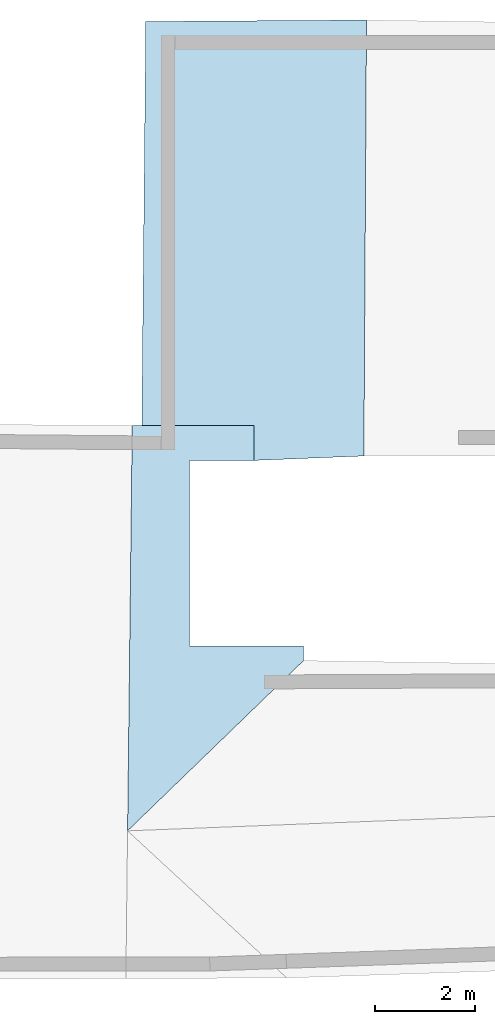
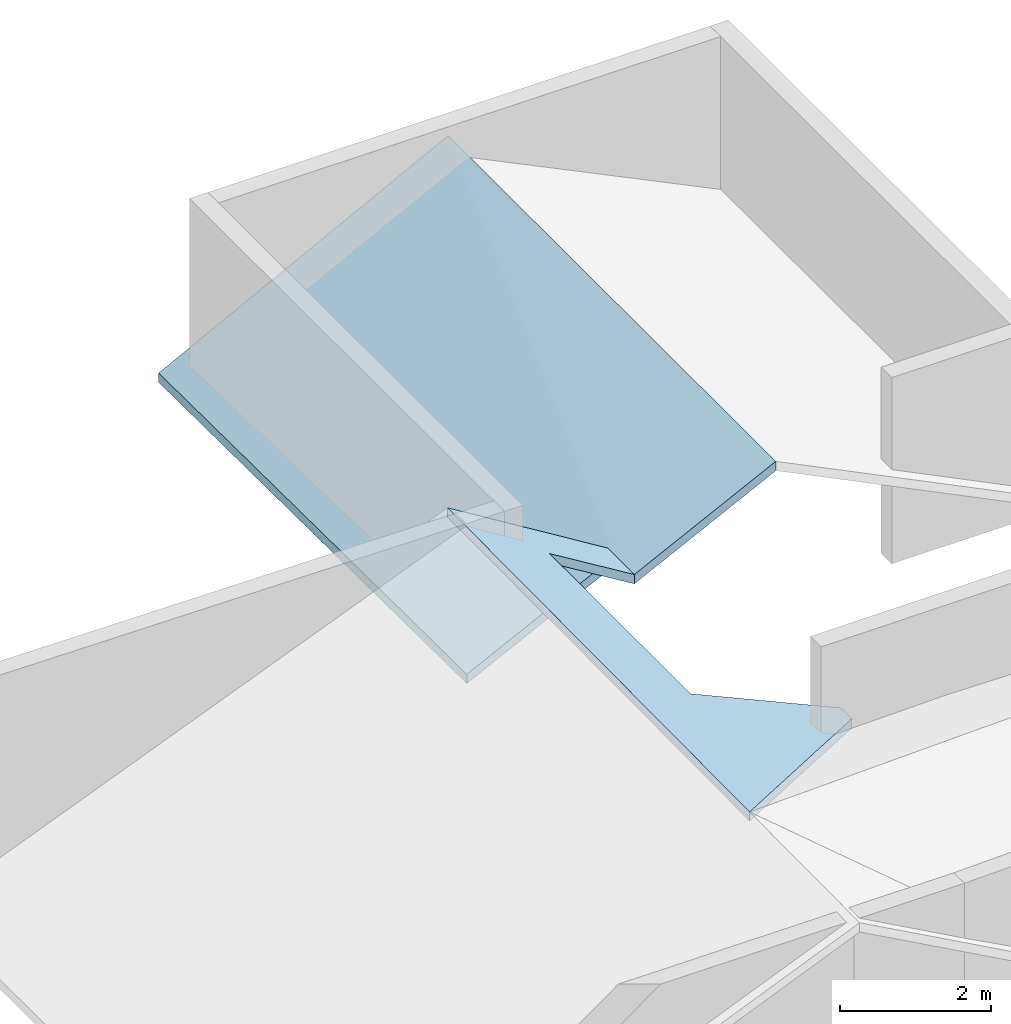
# One storey, part 2 of 2: 2 slabs.
"""IFC4 building model written with IfcOpenShell, lengths in metres."""

from ifc_helpers import new_model, entity, si_unit, converted_unit, frame, frame_2d, origin_with_axes, place, context, subcontext, project, spatial, polygons, element, save


model = new_model("IFC4")

# Units and contexts
model_context = context("Model", 3, precision=1e-05, world=origin_with_axes())
plan_context = context("Plan", 2, precision=1e-05, world=frame_2d((0.0, 0.0, 0.0), x_axis=(1.0, 0.0, 0.0)))
body_context = subcontext(model_context, "Body", "Model", "MODEL_VIEW")
ifc_project = project(units=[converted_unit("PLANEANGLEUNIT", "degree", entity("IfcReal", 0.0174532925199433), si_unit("PLANEANGLEUNIT", "RADIAN"), dimensions=[0, 0, 0, 0, 0, 0, 0]), si_unit("AREAUNIT", "SQUARE_METRE"), si_unit("VOLUMEUNIT", "CUBIC_METRE"), si_unit("LENGTHUNIT", "METRE")], contexts=[model_context, plan_context])

# Site, building, storey
site_placement = place(None, origin_with_axes())
site = spatial("IfcSite", under=ifc_project, at=site_placement)
building_placement = place(site_placement, origin_with_axes())
building = spatial("IfcBuilding", under=site, at=building_placement, Name="Building")
storey_placement = place(building_placement, frame((0.0, 0.0, 3.0), z_axis=(0.0, 0.0, 1.0), x_axis=(1.0, 0.0, 0.0)))
storey = spatial("IfcBuildingStorey", under=building, at=storey_placement, Name="Dachgeschoss")

# Slabs
slab_1_placement = place(storey_placement, frame((26.8203887939453, 9.78442668914795, -2.06702888011932), z_axis=(0.0, 0.0, 1.0), x_axis=(1.0, 0.0, 0.0)))
element("IfcSlab", 1, at=slab_1_placement, inside=storey, Name="dach_wohnen_w", PredefinedType="ROOF", context=body_context, shape_type="Tessellation", body=[
    polygons([(-18.3055820465088, -6.04181098937988, 5.09152317047119), (-14.7738656997681, -2.62468528747559, 3.28549098968506), (-18.2124099731445, 2.09556102752686, 5.02737331390381), (-17.0658378601074, 1.3901504278183, 4.31534337997437), (-15.7722063064575, 1.39000952243805, 3.52441787719727), (-15.7722063064575, 2.09556126594543, 3.52441787719727), (-14.7738656997681, -2.33506321907043, 3.28549098968506), (-17.0658378601074, -2.33499145507813, 4.31534337997437), (-18.2124099731445, 2.09556102752686, 4.87737321853638), (-18.3055820465088, -6.04181098937988, 4.94152307510376), (-14.7738656997681, -2.62468528747559, 3.13549089431763), (-15.7722063064575, 2.09556126594543, 3.37441778182983), (-17.0658378601074, 1.3901504278183, 4.16534328460693), (-15.7722063064575, 1.39000952243805, 3.37441778182983), (-14.7738656997681, -2.33506321907043, 3.13549089431763), (-17.0658378601074, -2.33499145507813, 4.16534328460693)], [[[1, 3, 8]], [[16, 13, 9]], [[7, 8, 16, 15]], [[5, 6, 12, 14]], [[6, 3, 9, 12]], [[3, 10, 9]], [[4, 16, 8]], [[2, 7, 15, 11]], [[4, 5, 14, 13]], [[1, 2, 11, 10]], [[3, 6, 4]], [[6, 5, 4]], [[7, 2, 8]], [[2, 1, 8]], [[3, 4, 8]], [[10, 11, 16]], [[11, 15, 16]], [[14, 12, 13]], [[12, 9, 13]], [[10, 16, 9]], [[3, 1, 10]], [[4, 13, 16]]]),
])
slab_2_placement = place(storey_placement, frame((11.5073595046997, 19.0338859558105, -0.612094879150391), z_axis=(0.0, 0.0, 1.0), x_axis=(1.0, 0.0, 0.0)))
element("IfcSlab", 2, at=slab_2_placement, inside=storey, Name="dach_so", PredefinedType="ROOF", context=body_context, shape_type="Tessellation", body=[
    polygons([(-2.97228264808655, -7.43174934387207, 0.821340084075928), (1.74949443340302, -7.77036571502686, 3.06659126281738), (-2.62752819061279, 0.947076737880707, 0.736433267593384), (1.80188846588135, 0.977355897426605, 2.99584007263184), (-0.459177732467651, -7.85944890975952, 2.06948375701904), (-2.70927309989929, -7.33231735229492, 0.930184245109558), (-0.459176629781723, -7.35307836532593, 2.06948399543762), (1.74949443340302, -7.77036571502686, 2.91659116744995), (1.80188846588135, 0.977355897426605, 2.8458399772644), (-2.62752819061279, 0.947076737880707, 0.586433291435242), (-2.70927309989929, -7.33231735229492, 0.780184268951416), (-0.459177732467651, -7.85944890975952, 1.9194837808609), (-0.459176629781723, -7.35307836532593, 1.91948401927948)], [[[2, 5, 7]], [[9, 10, 13]], [[6, 7, 13, 11]], [[4, 3, 10, 9]], [[3, 6, 11, 10]], [[5, 2, 8, 12]], [[7, 5, 12, 13]], [[2, 4, 9, 8]], [[7, 6, 3]], [[3, 4, 7]], [[4, 2, 7]], [[10, 11, 13]], [[13, 12, 8]], [[8, 9, 13]]]),
])

save(model, "model.ifc")
